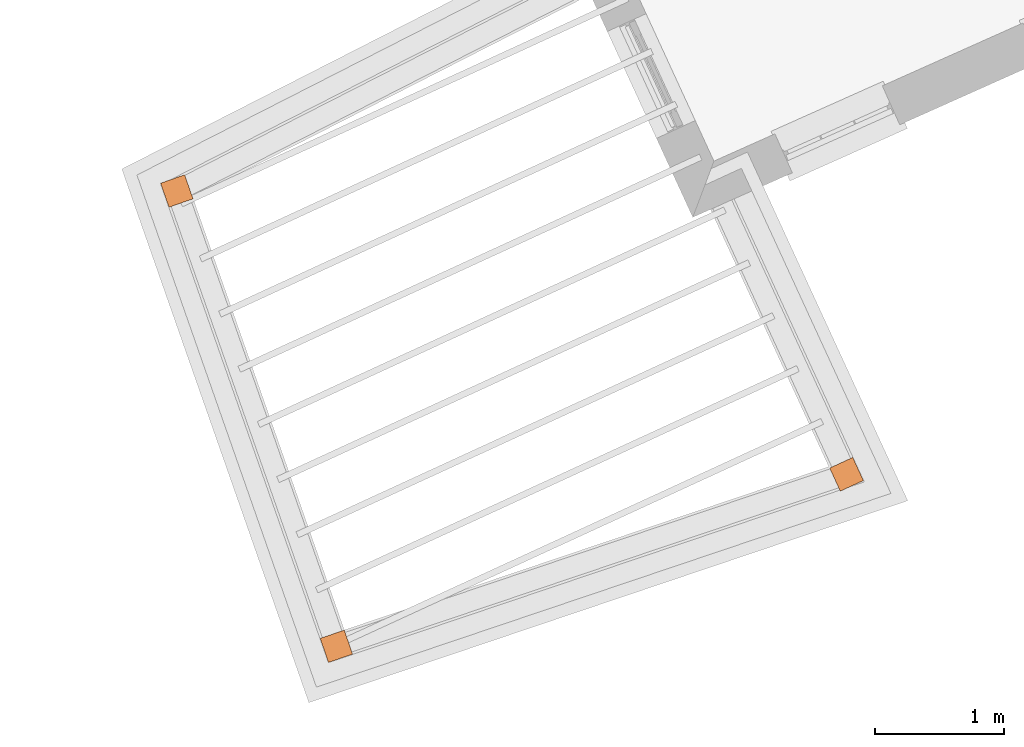
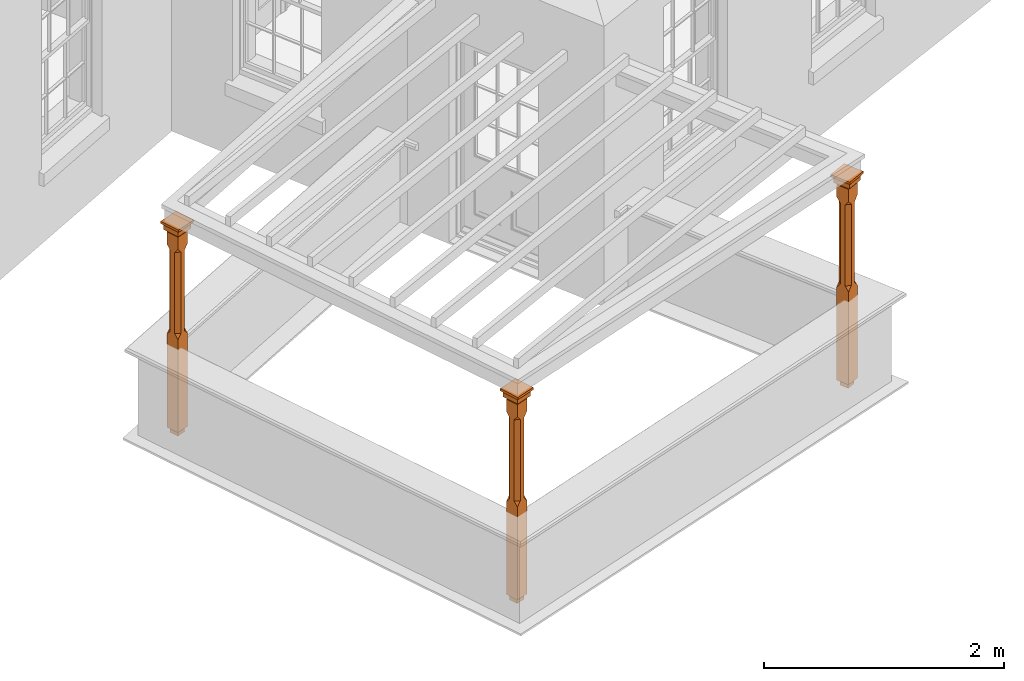
# One storey, part 9 of 9: 3 proxies.
"""IFC2X3 building model written with IfcOpenShell, lengths in metres."""

from ifc_helpers import new_model, si_unit, frame, origin, place, context, subcontext, project, spatial, faceted_brep, element, save


model = new_model("IFC2X3")

# Units and contexts
model_context = context("Model", 3, world=origin())
body_context = subcontext(model_context, "Body", "Model", "MODEL_VIEW")
ifc_project = project(units=[si_unit("PLANEANGLEUNIT", "RADIAN"), si_unit("MASSUNIT", "GRAM", prefix="KILO"), si_unit("FORCEUNIT", "NEWTON", prefix="KILO"), si_unit("LENGTHUNIT", "METRE")], contexts=[model_context])

# Site, building, storey
site_placement = place(None, origin())
site = spatial("IfcSite", under=ifc_project, at=site_placement, CompositionType="ELEMENT")
building_placement = place(None, origin())
building = spatial("IfcBuilding", under=site, at=building_placement, Name="Building plot-8", CompositionType="ELEMENT")
storey_placement = place(None, frame((0.0, 0.0, 3.45)))
storey = spatial("IfcBuildingStorey", under=building, at=storey_placement, Name="Floor 1", CompositionType="ELEMENT", Elevation=3.45)

# Proxies
proxy_1_placement = place(storey_placement, frame((21.5356027967568, 8.90372464572931, 0.0), z_axis=(0.0, 0.0, 1.0), x_axis=(0.330769763437975, -0.943711483237958, 0.0)))
element("IfcBuildingElementProxy", 1, at=proxy_1_placement, inside=storey, Name="pergola post", CompositionType="ELEMENT", context=body_context, shape_type="Brep", held_by="IfcProductRepresentation", body=[
    faceted_brep([(0.0246, -0.0615, 1.87), (0.0615, -0.0246, 1.87), (0.0615, -0.0615, 1.916667), (0.0615, -0.0246, 1.044444), (0.0246, -0.0615, 1.044444), (0.0615, 0.0246, 1.87), (0.0615, 0.0615, 1.916667), (-0.0246, -0.0615, 1.87), (-0.0615, -0.0615, 1.916667), (-0.0246, -0.0615, 1.044444), (0.0615, -0.0615, 0.997778), (0.0615, 0.0246, 1.044444), (0.0246, 0.0615, 1.87), (0.0615, 0.0615, 2.041111), (0.0615, -0.0615, 2.041111), (-0.0615, -0.0615, 2.041111), (-0.0615, -0.0246, 1.87), (-0.0615, -0.0246, 1.044444), (-0.0615, -0.0615, 0.997778), (0.0615, 0.0615, 0.997778), (0.0246, 0.0615, 1.044444), (-0.0246, 0.0615, 1.87), (-0.0615, 0.0615, 1.916667), (0.04305, 0.04305, 2.041111), (0.04305, -0.04305, 2.041111), (-0.0615, 0.0615, 2.041111), (-0.04305, -0.04305, 2.041111), (-0.0615, 0.0246, 1.87), (-0.0615, 0.0246, 1.044444), (0.0615, -0.0615, 0.053333), (-0.0615, -0.0615, 0.053333), (0.0615, 0.0615, 0.053333), (-0.0246, 0.0615, 1.044444), (-0.04305, 0.04305, 2.041111), (0.04305, 0.04305, 2.064444), (0.04305, -0.04305, 2.064444), (-0.04305, -0.04305, 2.064444), (-0.0615, 0.0615, 0.997778), (-0.0615, 0.0615, 0.053333), (-0.04305, -0.04305, 0.053333), (0.04305, -0.04305, 0.053333), (0.04305, 0.04305, 0.053333), (-0.04305, 0.04305, 2.064444), (0.07995, 0.07995, 2.064444), (0.07995, -0.07995, 2.064444), (-0.07995, -0.07995, 2.064444), (-0.04305, 0.04305, 0.053333), (-0.04305, -0.04305, 0.0), (0.04305, -0.04305, 0.0), (0.04305, 0.04305, 0.0), (-0.07995, 0.07995, 2.064444), (0.07995, 0.07995, 2.126667), (0.07995, -0.07995, 2.126667), (-0.07995, -0.07995, 2.126667), (-0.04305, 0.04305, 0.0), (-0.07995, 0.07995, 2.126667), (0.0984, 0.0984, 2.126667), (0.0984, -0.0984, 2.126667), (-0.0984, -0.0984, 2.126667), (-0.0984, 0.0984, 2.126667), (0.0984, 0.0984, 2.15), (0.0984, -0.0984, 2.15), (-0.0984, -0.0984, 2.15), (-0.0984, 0.0984, 2.15)], [[[0, 1, 2]], [[3, 1, 0, 4]], [[1, 5, 6, 2]], [[7, 0, 2, 8]], [[4, 0, 7, 9]], [[3, 4, 10]], [[1, 3, 11, 5]], [[5, 12, 6]], [[13, 14, 2, 6]], [[15, 8, 2, 14]], [[8, 16, 7]], [[9, 7, 16, 17]], [[9, 18, 10, 4]], [[3, 10, 19, 11]], [[20, 12, 5, 11]], [[21, 22, 6, 12]], [[14, 13, 23, 24]], [[13, 6, 22, 25]], [[25, 22, 8, 15]], [[26, 15, 14, 24]], [[16, 8, 22, 27]], [[27, 28, 17, 16]], [[17, 18, 9]], [[29, 10, 18, 30]], [[31, 19, 10, 29]], [[20, 11, 19]], [[12, 20, 32, 21]], [[21, 27, 22]], [[33, 23, 13, 25]], [[23, 34, 35, 24]], [[26, 33, 25, 15]], [[36, 26, 24, 35]], [[28, 27, 21, 32]], [[17, 28, 37, 18]], [[38, 30, 18, 37]], [[29, 30, 39, 40]], [[31, 38, 37, 19]], [[40, 41, 31, 29]], [[32, 20, 19, 37]], [[33, 42, 34, 23]], [[43, 44, 35, 34]], [[42, 33, 26, 36]], [[36, 35, 44, 45]], [[28, 32, 37]], [[46, 39, 30, 38]], [[39, 47, 48, 40]], [[46, 38, 31, 41]], [[49, 41, 40, 48]], [[43, 34, 42, 50]], [[43, 51, 52, 44]], [[45, 50, 42, 36]], [[53, 45, 44, 52]], [[46, 54, 47, 39]], [[54, 46, 41, 49]], [[50, 55, 51, 43]], [[56, 57, 52, 51]], [[55, 50, 45, 53]], [[53, 52, 57, 58]], [[56, 51, 55, 59]], [[56, 60, 61, 57]], [[58, 59, 55, 53]], [[62, 58, 57, 61]], [[59, 63, 60, 56]], [[63, 62, 61, 60]], [[58, 62, 63, 59]], [[47, 54, 49, 48]]]),
])
proxy_2_placement = place(storey_placement, frame((22.769491488676, 5.383345650084, 0.0), z_axis=(0.0, 0.0, 1.0), x_axis=(0.947596583973755, 0.319469425831754, 0.0)))
element("IfcBuildingElementProxy", 2, at=proxy_2_placement, inside=storey, Name="pergola post", CompositionType="ELEMENT", context=body_context, shape_type="Brep", held_by="IfcProductRepresentation", body=[
    faceted_brep([(0.0246, -0.0615, 1.87), (0.0615, -0.0246, 1.87), (0.0615, -0.0615, 1.916667), (0.0615, -0.0246, 1.044444), (0.0246, -0.0615, 1.044444), (0.0615, 0.0246, 1.87), (0.0615, 0.0615, 1.916667), (-0.0246, -0.0615, 1.87), (-0.0615, -0.0615, 1.916667), (-0.0246, -0.0615, 1.044444), (0.0615, -0.0615, 0.997778), (0.0615, 0.0246, 1.044444), (0.0246, 0.0615, 1.87), (0.0615, 0.0615, 2.041111), (0.0615, -0.0615, 2.041111), (-0.0615, -0.0615, 2.041111), (-0.0615, -0.0246, 1.87), (-0.0615, -0.0246, 1.044444), (-0.0615, -0.0615, 0.997778), (0.0615, 0.0615, 0.997778), (0.0246, 0.0615, 1.044444), (-0.0246, 0.0615, 1.87), (-0.0615, 0.0615, 1.916667), (0.04305, 0.04305, 2.041111), (0.04305, -0.04305, 2.041111), (-0.0615, 0.0615, 2.041111), (-0.04305, -0.04305, 2.041111), (-0.0615, 0.0246, 1.87), (-0.0615, 0.0246, 1.044444), (0.0615, -0.0615, 0.053333), (-0.0615, -0.0615, 0.053333), (0.0615, 0.0615, 0.053333), (-0.0246, 0.0615, 1.044444), (-0.04305, 0.04305, 2.041111), (0.04305, 0.04305, 2.064444), (0.04305, -0.04305, 2.064444), (-0.04305, -0.04305, 2.064444), (-0.0615, 0.0615, 0.997778), (-0.0615, 0.0615, 0.053333), (-0.04305, -0.04305, 0.053333), (0.04305, -0.04305, 0.053333), (0.04305, 0.04305, 0.053333), (-0.04305, 0.04305, 2.064444), (0.07995, 0.07995, 2.064444), (0.07995, -0.07995, 2.064444), (-0.07995, -0.07995, 2.064444), (-0.04305, 0.04305, 0.053333), (-0.04305, -0.04305, 0.0), (0.04305, -0.04305, 0.0), (0.04305, 0.04305, 0.0), (-0.07995, 0.07995, 2.064444), (0.07995, 0.07995, 2.126667), (0.07995, -0.07995, 2.126667), (-0.07995, -0.07995, 2.126667), (-0.04305, 0.04305, 0.0), (-0.07995, 0.07995, 2.126667), (0.0984, 0.0984, 2.126667), (0.0984, -0.0984, 2.126667), (-0.0984, -0.0984, 2.126667), (-0.0984, 0.0984, 2.126667), (0.0984, 0.0984, 2.15), (0.0984, -0.0984, 2.15), (-0.0984, -0.0984, 2.15), (-0.0984, 0.0984, 2.15)], [[[0, 1, 2]], [[3, 1, 0, 4]], [[1, 5, 6, 2]], [[7, 0, 2, 8]], [[4, 0, 7, 9]], [[3, 4, 10]], [[1, 3, 11, 5]], [[5, 12, 6]], [[13, 14, 2, 6]], [[15, 8, 2, 14]], [[8, 16, 7]], [[9, 7, 16, 17]], [[9, 18, 10, 4]], [[3, 10, 19, 11]], [[20, 12, 5, 11]], [[21, 22, 6, 12]], [[14, 13, 23, 24]], [[13, 6, 22, 25]], [[25, 22, 8, 15]], [[26, 15, 14, 24]], [[16, 8, 22, 27]], [[27, 28, 17, 16]], [[17, 18, 9]], [[29, 10, 18, 30]], [[31, 19, 10, 29]], [[20, 11, 19]], [[12, 20, 32, 21]], [[21, 27, 22]], [[33, 23, 13, 25]], [[23, 34, 35, 24]], [[26, 33, 25, 15]], [[36, 26, 24, 35]], [[28, 27, 21, 32]], [[17, 28, 37, 18]], [[38, 30, 18, 37]], [[29, 30, 39, 40]], [[31, 38, 37, 19]], [[40, 41, 31, 29]], [[32, 20, 19, 37]], [[33, 42, 34, 23]], [[43, 44, 35, 34]], [[42, 33, 26, 36]], [[36, 35, 44, 45]], [[28, 32, 37]], [[46, 39, 30, 38]], [[39, 47, 48, 40]], [[46, 38, 31, 41]], [[49, 41, 40, 48]], [[43, 34, 42, 50]], [[43, 51, 52, 44]], [[45, 50, 42, 36]], [[53, 45, 44, 52]], [[46, 54, 47, 39]], [[54, 46, 41, 49]], [[50, 55, 51, 43]], [[56, 57, 52, 51]], [[55, 50, 45, 53]], [[53, 52, 57, 58]], [[56, 51, 55, 59]], [[56, 60, 61, 57]], [[58, 59, 55, 53]], [[62, 58, 57, 61]], [[59, 63, 60, 56]], [[63, 62, 61, 60]], [[58, 62, 63, 59]], [[47, 54, 49, 48]]]),
])
proxy_3_placement = place(storey_placement, frame((26.7145237601106, 6.71336014777014, 0.0), z_axis=(0.0, 0.0, 1.0), x_axis=(-0.417898615670256, 0.908493669224439, 0.0)))
element("IfcBuildingElementProxy", 3, at=proxy_3_placement, inside=storey, Name="pergola post", CompositionType="ELEMENT", context=body_context, shape_type="Brep", held_by="IfcProductRepresentation", body=[
    faceted_brep([(0.0246, -0.0615, 1.87), (0.0615, -0.0246, 1.87), (0.0615, -0.0615, 1.916667), (0.0615, -0.0246, 1.044444), (0.0246, -0.0615, 1.044444), (0.0615, 0.0246, 1.87), (0.0615, 0.0615, 1.916667), (-0.0246, -0.0615, 1.87), (-0.0615, -0.0615, 1.916667), (-0.0246, -0.0615, 1.044444), (0.0615, -0.0615, 0.997778), (0.0615, 0.0246, 1.044444), (0.0246, 0.0615, 1.87), (0.0615, 0.0615, 2.041111), (0.0615, -0.0615, 2.041111), (-0.0615, -0.0615, 2.041111), (-0.0615, -0.0246, 1.87), (-0.0615, -0.0246, 1.044444), (-0.0615, -0.0615, 0.997778), (0.0615, 0.0615, 0.997778), (0.0246, 0.0615, 1.044444), (-0.0246, 0.0615, 1.87), (-0.0615, 0.0615, 1.916667), (0.04305, 0.04305, 2.041111), (0.04305, -0.04305, 2.041111), (-0.0615, 0.0615, 2.041111), (-0.04305, -0.04305, 2.041111), (-0.0615, 0.0246, 1.87), (-0.0615, 0.0246, 1.044444), (0.0615, -0.0615, 0.053333), (-0.0615, -0.0615, 0.053333), (0.0615, 0.0615, 0.053333), (-0.0246, 0.0615, 1.044444), (-0.04305, 0.04305, 2.041111), (0.04305, 0.04305, 2.064444), (0.04305, -0.04305, 2.064444), (-0.04305, -0.04305, 2.064444), (-0.0615, 0.0615, 0.997778), (-0.0615, 0.0615, 0.053333), (-0.04305, -0.04305, 0.053333), (0.04305, -0.04305, 0.053333), (0.04305, 0.04305, 0.053333), (-0.04305, 0.04305, 2.064444), (0.07995, 0.07995, 2.064444), (0.07995, -0.07995, 2.064444), (-0.07995, -0.07995, 2.064444), (-0.04305, 0.04305, 0.053333), (-0.04305, -0.04305, 0.0), (0.04305, -0.04305, 0.0), (0.04305, 0.04305, 0.0), (-0.07995, 0.07995, 2.064444), (0.07995, 0.07995, 2.126667), (0.07995, -0.07995, 2.126667), (-0.07995, -0.07995, 2.126667), (-0.04305, 0.04305, 0.0), (-0.07995, 0.07995, 2.126667), (0.0984, 0.0984, 2.126667), (0.0984, -0.0984, 2.126667), (-0.0984, -0.0984, 2.126667), (-0.0984, 0.0984, 2.126667), (0.0984, 0.0984, 2.15), (0.0984, -0.0984, 2.15), (-0.0984, -0.0984, 2.15), (-0.0984, 0.0984, 2.15)], [[[0, 1, 2]], [[3, 1, 0, 4]], [[1, 5, 6, 2]], [[7, 0, 2, 8]], [[4, 0, 7, 9]], [[3, 4, 10]], [[1, 3, 11, 5]], [[5, 12, 6]], [[13, 14, 2, 6]], [[15, 8, 2, 14]], [[8, 16, 7]], [[9, 7, 16, 17]], [[9, 18, 10, 4]], [[3, 10, 19, 11]], [[20, 12, 5, 11]], [[21, 22, 6, 12]], [[14, 13, 23, 24]], [[13, 6, 22, 25]], [[25, 22, 8, 15]], [[26, 15, 14, 24]], [[16, 8, 22, 27]], [[27, 28, 17, 16]], [[17, 18, 9]], [[29, 10, 18, 30]], [[31, 19, 10, 29]], [[20, 11, 19]], [[12, 20, 32, 21]], [[21, 27, 22]], [[33, 23, 13, 25]], [[23, 34, 35, 24]], [[26, 33, 25, 15]], [[36, 26, 24, 35]], [[28, 27, 21, 32]], [[17, 28, 37, 18]], [[38, 30, 18, 37]], [[29, 30, 39, 40]], [[31, 38, 37, 19]], [[40, 41, 31, 29]], [[32, 20, 19, 37]], [[33, 42, 34, 23]], [[43, 44, 35, 34]], [[42, 33, 26, 36]], [[36, 35, 44, 45]], [[28, 32, 37]], [[46, 39, 30, 38]], [[39, 47, 48, 40]], [[46, 38, 31, 41]], [[49, 41, 40, 48]], [[43, 34, 42, 50]], [[43, 51, 52, 44]], [[45, 50, 42, 36]], [[53, 45, 44, 52]], [[46, 54, 47, 39]], [[54, 46, 41, 49]], [[50, 55, 51, 43]], [[56, 57, 52, 51]], [[55, 50, 45, 53]], [[53, 52, 57, 58]], [[56, 51, 55, 59]], [[56, 60, 61, 57]], [[58, 59, 55, 53]], [[62, 58, 57, 61]], [[59, 63, 60, 56]], [[63, 62, 61, 60]], [[58, 62, 63, 59]], [[47, 54, 49, 48]]]),
])

save(model, "model.ifc")
